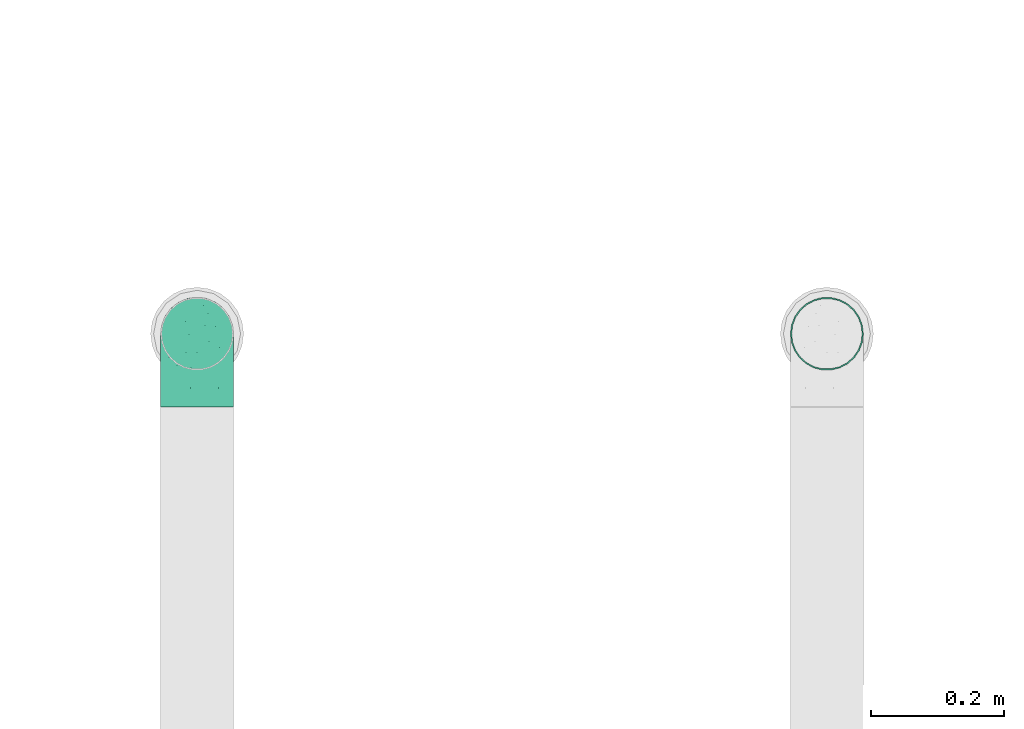
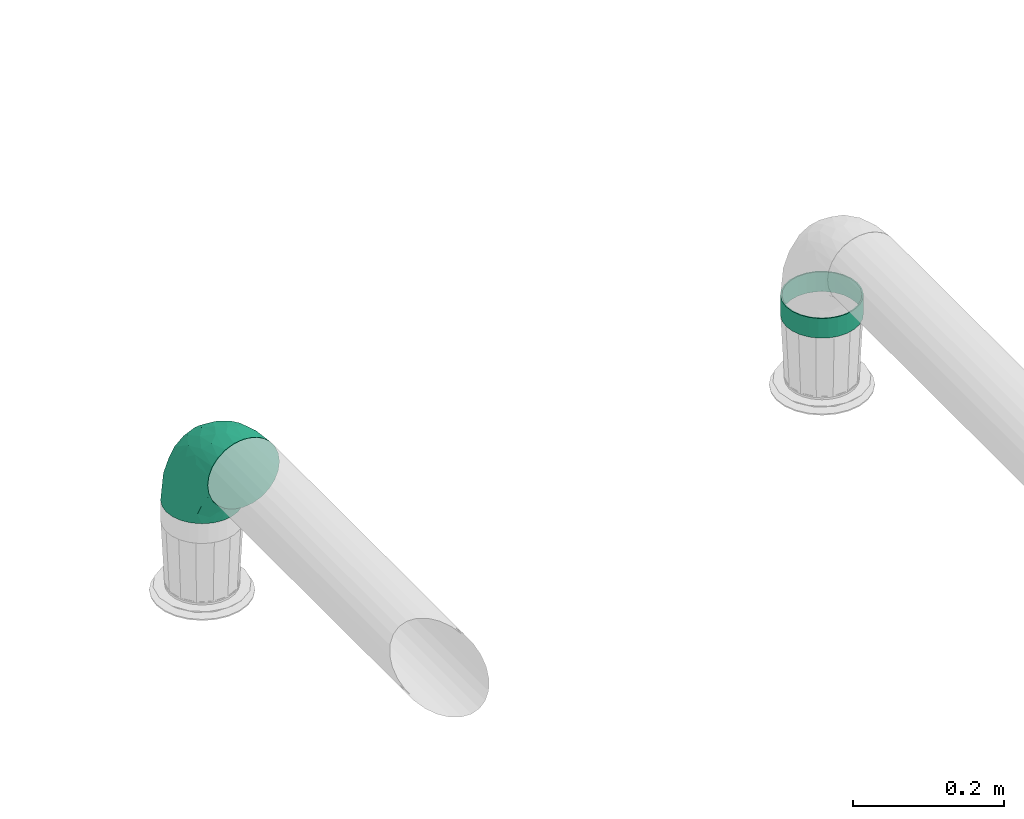
# One storey, part 43 of 123: 1 flow fitting, 1 flow segment.
"""IFC2X3 building model written with IfcOpenShell, lengths in millimetres."""

from ifc_helpers import new_model, entity, si_unit, converted_unit, derived_unit, direction, frame, origin_with_axes, origin_2d_with_axis, place, context, subcontext, project, spatial, hollow_circle, extrude, open_shell, surface_model, source, transform, mapped, material, layer, layer_set, layer_usage, type_object, element, save


model = new_model("IFC2X3")

# Units and contexts
model_context = context("Model", 3, precision=1e-05, world=origin_with_axes(), true_north=direction((0.0, 1.0)))
body_context = subcontext(model_context, "Body", "Model", "MODEL_VIEW")
ifc_project = project(units=[si_unit("AREAUNIT", "SQUARE_METRE"), si_unit("VOLUMEUNIT", "CUBIC_METRE", prefix="DECI"), si_unit("TIMEUNIT", "SECOND"), si_unit("THERMODYNAMICTEMPERATUREUNIT", "DEGREE_CELSIUS"), si_unit("PRESSUREUNIT", "PASCAL"), si_unit("MASSUNIT", "GRAM", prefix="KILO"), si_unit("LENGTHUNIT", "METRE", prefix="MILLI"), si_unit("POWERUNIT", "WATT"), si_unit("ELECTRICCURRENTUNIT", "AMPERE"), si_unit("ELECTRICVOLTAGEUNIT", "VOLT"), derived_unit("VOLUMETRICFLOWRATEUNIT", [(si_unit("VOLUMEUNIT", "CUBIC_METRE", prefix="DECI"), 1), (si_unit("TIMEUNIT", "SECOND"), -1)]), derived_unit("LINEARVELOCITYUNIT", [(si_unit("LENGTHUNIT", "METRE"), 1), (si_unit("TIMEUNIT", "SECOND"), -1)]), derived_unit("MASSDENSITYUNIT", [(si_unit("MASSUNIT", "GRAM", prefix="KILO"), 1), (si_unit("VOLUMEUNIT", "CUBIC_METRE"), -1)]), converted_unit("PLANEANGLEUNIT", "DEGREE", entity("IfcRatioMeasure", 0.01745), si_unit("PLANEANGLEUNIT", "RADIAN"), dimensions=[0, 0, 0, 0, 0, 0, 0])], contexts=[model_context])

# Site, building, storey
site_placement = place(None, origin_with_axes())
site = spatial("IfcSite", under=ifc_project, at=site_placement, CompositionType="ELEMENT")
building_placement = place(site_placement, origin_with_axes())
building = spatial("IfcBuilding", under=site, at=building_placement, Name="mc-building", CompositionType="ELEMENT")
storey_placement = place(building_placement, origin_with_axes())
storey = spatial("IfcBuildingStorey", under=building, at=storey_placement, Name="1. Korrus", CompositionType="ELEMENT", Elevation=0.0)

# Flow segment
ifc_material = material(Name="FZ1")
ifc_layer = layer(ifc_material, 0.0)
ifc_layer_set = layer_set([ifc_layer], Name="FZ1")
ifc_layer_usage = layer_usage(ifc_layer_set, "AXIS1", "POSITIVE", 0.0)
duct_segment_type = type_object("IfcDuctSegmentType", PredefinedType="RIGIDSEGMENT")
shared_shape_1 = source(origin_with_axes(), body_context, "Body", "SweptSolid", [
    extrude(hollow_circle(Radius=55.0, WallThickness=2.0, at=origin_2d_with_axis()), frame((0.0, 0.0, 0.0), z_axis=(1.0, 0.0, 0.0), x_axis=(0.0, 1.0, 0.0)), (0.0, 0.0, 1.0), 31.9),
])
flow_segment_placement = place(storey_placement, frame((16466.11947, 4715.81442, 2335.0), z_axis=(0.0, 1.0, 0.0), x_axis=(0.0, 0.0, -1.0)))
element("IfcFlowSegment", 1, at=flow_segment_placement, inside=storey, type_object=duct_segment_type, material=ifc_layer_usage, context=body_context, shape_type="MappedRepresentation", body=[
    mapped(shared_shape_1, transform((0.0, 0.0, 0.0), scale=1.0)),
])

# Flow fitting
duct_fitting_type = type_object("IfcDuctFittingType", Name="BU", PredefinedType="BEND")
shared_shape_2 = source(origin_with_axes(), body_context, "Body", "SurfaceModel", [
    surface_model("IfcShellBasedSurfaceModel", [(-110.0, -38.89087, -38.89087), (-110.0, -55.0, 0.0), (-110.0, -27.5, -47.63139), (-110.0, -53.12592, -14.23505), (-110.0, -47.63139, -27.5), (-110.0, 47.63139, -27.5), (-110.0, 53.12592, 14.23505), (-110.0, 53.12592, -14.23505), (-110.0, -14.23505, -53.12592), (-110.0, 0.0, -55.0), (-110.0, 38.89087, -38.89087), (-110.0, 27.5, -47.63139), (-110.0, 14.23505, -53.12592), (-110.0, 55.0, 0.0), (-110.0, -53.12592, 14.23505), (-110.0, -47.63139, 27.5), (-110.0, -38.89087, 38.89087), (-110.0, 0.0, 55.0), (-110.0, -27.5, 47.63139), (-110.0, -14.23505, 53.12592), (-110.0, 38.89087, 38.89087), (-110.0, 47.63139, 27.5), (-110.0, 27.5, 47.63139), (-110.0, 14.23505, 53.12592), (0.0, -110.0, -55.0), (14.23505, -110.0, -53.12592), (-14.23505, -110.0, -53.12592), (-53.12592, -110.0, 14.23505), (-27.5, -110.0, -47.63139), (-47.63139, -110.0, -27.5), (-38.89087, -110.0, -38.89087), (55.0, -110.0, 0.0), (53.12592, -110.0, 14.23505), (38.89087, -110.0, -38.89087), (27.5, -110.0, -47.63139), (53.12592, -110.0, -14.23505), (47.63139, -110.0, -27.5), (-53.12592, -110.0, -14.23505), (-47.63139, -110.0, 27.5), (-38.89087, -110.0, 38.89087), (14.23505, -110.0, 53.12592), (-27.5, -110.0, 47.63139), (-14.23505, -110.0, 53.12592), (47.63139, -110.0, 27.5), (38.89087, -110.0, 38.89087), (27.5, -110.0, 47.63139), (0.0, -110.0, 55.0), (-55.0, -110.0, 0.0), (-60.44912, -32.56953, 51.94617), (-76.6405, -38.18013, 45.55988), (-64.21732, -48.68956, 43.63444), (-90.15553, -11.94394, 54.09138), (-76.00813, -5.38378, 55.0), (-70.18771, -18.55163, 54.03432), (-78.5998, -26.77405, 50.81338), (-93.27622, -45.77614, 33.48188), (-75.55424, -54.2118, 32.41257), (-96.12334, -22.13664, 50.81337), (-32.04182, -59.64019, 52.24446), (-18.36258, -70.48427, 54.04484), (-21.00813, -45.34362, 55.0), (-63.60674, -66.07878, 29.97482), (-74.66383, -63.08407, 19.92123), (-63.88653, -74.77858, 17.99134), (-93.11138, -56.59448, 10.50359), (-99.597, -52.72185, 18.52927), (-98.21577, -57.34403, 0.0), (-53.42855, -92.60092, 21.04759), (-88.54852, -54.8376, 21.04759), (-5.38378, -76.00813, 55.0), (-11.86161, -90.23965, 54.10313), (-56.64619, -93.12774, 10.22088), (-57.34403, -98.21577, 0.0), (-44.60838, -44.60838, 52.13415), (-45.34362, -21.00813, 55.0), (-92.68484, -35.46673, 43.63443), (-22.25266, -95.40765, 50.81337), (-27.23711, -77.39884, 50.81337), (-43.70931, -69.58671, 44.47149), (-35.97783, -90.61597, 43.63443), (-58.67786, -84.31125, 16.04456), (-57.2828, -79.3123, 24.9774), (-82.93277, -60.36161, 12.91784), (-49.88337, -54.51816, 47.224), (-74.57753, -66.83759, 9.55742), (-45.35812, -94.97281, 33.48188), (-59.18663, -88.95241, 0.0), (-51.517, -78.6292, 33.48188), (-65.14788, -80.03077, 0.0), (-56.45322, -62.06476, 39.63545), (-88.95241, -59.18663, 0.0), (-80.03077, -65.14788, 0.0), (-71.10913, -71.10913, 0.0), (-94.9309, -45.36788, -33.48188), (-93.11358, -56.60141, -10.46614), (-99.64997, -52.79499, -18.30015), (-79.99933, -46.56772, -37.92748), (-90.20425, -36.08686, -43.63443), (-45.34362, -21.00813, -55.0), (-72.75364, -19.68651, -53.60527), (-76.00813, -5.38378, -55.0), (-21.00813, -45.34362, -55.0), (-5.38378, -76.00813, -55.0), (-21.91957, -65.12078, -53.85897), (-35.41876, -92.89265, -43.63443), (-91.10309, -11.02766, -54.21832), (-45.77614, -93.27622, -33.48188), (-90.50474, -23.21022, -50.81337), (-70.92854, -33.31794, -49.51754), (-78.52933, -63.35627, -11.73997), (-24.91508, -84.05606, -50.81337), (-88.78941, -54.74452, -21.04759), (-63.49062, -67.59111, -28.46929), (-73.36422, -62.46673, -22.94182), (-69.59921, -57.34866, -33.48187), (-56.59448, -93.11138, -10.50359), (-54.10679, -75.85581, -32.31867), (-54.8376, -88.54852, -21.04759), (-57.75956, -31.09612, -52.80882), (-52.72185, -99.597, -18.52927), (-12.62913, -89.46304, -53.99097), (-34.46825, -66.46123, -50.04329), (-43.9837, -43.9837, -52.42279), (-65.78527, -72.58348, -17.68796), (-57.47001, -51.99467, -44.91465), (-70.34468, -43.65295, -44.21951), (-60.72547, -82.29174, -12.88567), (-42.34915, -74.24548, -43.63444), (-57.25194, -63.5016, -38.08211), (-80.95344, -53.56991, -29.32027), (-52.32891, -4.55257, -54.0482), (14.95561, -36.05775, -42.26543), (14.88266, -20.92917, -33.7947), (32.52942, -47.13398, -30.48571), (19.3559, -65.35825, -48.00507), (30.24048, -70.09027, -41.7461), (-28.49299, 30.5778, -16.4009), (-47.13398, 32.52942, -30.48571), (-70.35075, 46.44478, -19.5952), (-22.4954, -22.4954, -53.25347), (-4.55257, -52.32891, -54.0482), (-75.47368, 11.22546, -52.60718), (-81.32209, 51.5606, -9.98467), (-70.09027, 30.24048, -41.7461), (-80.81763, 41.84862, -32.14655), (-9.15831, 10.852, -27.8997), (-36.05774, 14.95561, -42.26543), (-65.35825, 19.3559, -48.00507), (3.94376, -43.9333, -50.53315), (11.22546, -75.47368, -52.60718), (-43.9333, 3.94376, -50.53315), (-13.39742, -13.39743, -48.13058), (50.20582, -74.51695, -9.9731), (41.8609, -47.82256, -9.92641), (49.37776, -67.29486, 0.0), (18.93131, -11.7156, -17.56239), (-1.23348, 12.25375, -12.18106), (-27.5, 32.89419, 0.0), (41.84862, -80.81763, -32.14655), (46.44478, -70.35075, -19.5952), (35.70604, -41.31408, -20.38235), (6.67262, 6.67262, 0.0), (32.89419, -27.5, 0.0), (-50.36265, 42.95545, -9.51562), (-67.29486, 49.37776, 0.0), (-5.47251, -5.47251, -39.92906), (-70.35075, 46.44478, 19.5952), (-74.51695, 50.20582, 9.9731), (-47.13398, 32.52942, 30.48571), (-41.31407, 35.70604, 20.38235), (-80.81763, 41.84862, 32.14655), (11.22546, -75.47368, 52.60718), (-4.55257, -52.32891, 54.0482), (-36.05774, 14.95561, 42.26543), (-65.35825, 19.3559, 48.00507), (-43.9333, 3.94376, 50.53315), (-70.09027, 30.24048, 41.7461), (-11.7156, 18.93131, 17.56239), (12.25375, -1.23348, 12.18106), (30.5778, -28.49299, 16.4009), (42.95545, -50.36265, 9.51562), (51.5606, -81.32209, 9.98467), (-52.32891, -4.55257, 54.0482), (-75.47368, 11.22546, 52.60718), (-13.39742, -13.39743, 48.13058), (-22.4954, -22.4954, 53.25347), (3.94376, -43.9333, 50.53315), (-20.92916, 14.88266, 33.79469), (10.852, -9.15831, 27.8997), (-47.82256, 41.8609, 9.92641), (32.52942, -47.13398, 30.48571), (46.44478, -70.35075, 19.5952), (41.84862, -80.81763, 32.14655), (14.95561, -36.05775, 42.26543), (19.3559, -65.35825, 48.00507), (30.24048, -70.09027, 41.7461), (-5.47251, -5.47251, 39.92906)], [open_shell([[[0, 1, 2]], [[3, 1, 4]], [[5, 6, 7]], [[8, 1, 9]], [[2, 1, 8]], [[4, 1, 0]], [[10, 9, 6]], [[9, 10, 11]], [[11, 12, 9]], [[6, 5, 10]], [[7, 6, 13]], [[14, 15, 9]], [[9, 15, 16]], [[17, 16, 18]], [[9, 16, 17]], [[19, 17, 18]], [[9, 20, 21]], [[6, 9, 21]], [[9, 22, 20]], [[23, 22, 9]], [[17, 23, 9]], [[9, 1, 14]], [[24, 25, 26]], [[26, 27, 28]], [[29, 30, 27]], [[28, 27, 30]], [[26, 31, 32]], [[33, 31, 34]], [[25, 34, 31]], [[35, 31, 36]], [[33, 36, 31]], [[31, 26, 25]], [[29, 27, 37]], [[38, 27, 26]], [[39, 38, 26]], [[40, 41, 26]], [[41, 39, 26]], [[40, 42, 41]], [[43, 44, 26]], [[43, 26, 32]], [[44, 45, 26]], [[26, 45, 40]], [[40, 46, 42]], [[47, 37, 27]], [[48, 49, 50]], [[51, 52, 17]], [[48, 53, 54]], [[49, 55, 56]], [[16, 15, 55]], [[18, 57, 19]], [[58, 59, 60]], [[61, 62, 63]], [[64, 65, 14]], [[53, 51, 54]], [[66, 64, 14]], [[27, 38, 67]], [[65, 68, 55]], [[68, 65, 64]], [[69, 59, 70]], [[71, 72, 27]], [[73, 60, 74]], [[55, 49, 75]], [[42, 70, 76]], [[51, 57, 54]], [[77, 78, 79]], [[42, 76, 41]], [[46, 70, 42]], [[55, 68, 56]], [[75, 18, 16]], [[77, 79, 76]], [[80, 67, 81]], [[68, 82, 62]], [[83, 78, 58]], [[82, 84, 62]], [[39, 79, 85]], [[71, 67, 80]], [[72, 71, 86]], [[67, 85, 87]], [[88, 80, 63]], [[39, 41, 79]], [[87, 79, 78]], [[55, 75, 16]], [[50, 89, 83]], [[38, 39, 85]], [[56, 68, 62]], [[61, 87, 89]], [[48, 50, 83]], [[18, 75, 57]], [[54, 75, 49]], [[38, 85, 67]], [[85, 79, 87]], [[56, 62, 61]], [[50, 56, 89]], [[87, 61, 81]], [[90, 64, 66]], [[14, 1, 66]], [[91, 92, 84]], [[82, 90, 91]], [[90, 82, 64]], [[62, 84, 63]], [[84, 82, 91]], [[64, 82, 68]], [[65, 15, 14]], [[15, 65, 55]], [[72, 47, 27]], [[86, 71, 80]], [[67, 71, 27]], [[88, 63, 92]], [[63, 80, 81]], [[63, 81, 61]], [[87, 81, 67]], [[41, 76, 79]], [[70, 59, 77]], [[76, 70, 77]], [[69, 70, 46]], [[77, 59, 58]], [[59, 69, 60]], [[77, 58, 78]], [[73, 58, 60]], [[19, 57, 51]], [[54, 57, 75]], [[19, 51, 17]], [[53, 52, 51]], [[53, 74, 52]], [[73, 74, 48]], [[53, 48, 74]], [[83, 73, 48]], [[73, 83, 58]], [[78, 83, 89]], [[78, 89, 87]], [[61, 89, 56]], [[54, 49, 48]], [[50, 49, 56]], [[88, 86, 80]], [[63, 84, 92]], [[93, 4, 0]], [[66, 94, 90]], [[95, 94, 3]], [[96, 93, 97]], [[98, 99, 100]], [[0, 2, 97]], [[101, 102, 103]], [[104, 28, 30]], [[9, 105, 8]], [[30, 106, 104]], [[107, 105, 99]], [[97, 107, 108]], [[94, 109, 90]], [[2, 8, 107]], [[94, 66, 3]], [[110, 26, 28]], [[94, 111, 109]], [[112, 113, 114]], [[72, 115, 37]], [[116, 106, 117]], [[98, 118, 99]], [[119, 115, 117]], [[115, 119, 37]], [[110, 120, 26]], [[103, 110, 121]], [[117, 106, 119]], [[120, 110, 103]], [[98, 101, 122]], [[117, 123, 116]], [[108, 124, 125]], [[126, 117, 115]], [[30, 29, 106]], [[120, 102, 24]], [[110, 104, 127]], [[97, 125, 96]], [[118, 122, 124]], [[124, 127, 128]], [[93, 0, 97]], [[86, 126, 115]], [[127, 106, 116]], [[129, 113, 111]], [[4, 93, 95]], [[114, 129, 96]], [[28, 104, 110]], [[127, 104, 106]], [[2, 107, 97]], [[108, 107, 99]], [[118, 108, 99]], [[100, 99, 105]], [[128, 112, 114]], [[127, 124, 121]], [[66, 1, 3]], [[91, 90, 109]], [[95, 111, 94]], [[109, 123, 92]], [[114, 113, 129]], [[111, 95, 93]], [[95, 3, 4]], [[86, 115, 72]], [[37, 47, 72]], [[88, 92, 123]], [[123, 117, 126]], [[126, 88, 123]], [[88, 126, 86]], [[119, 29, 37]], [[29, 119, 106]], [[111, 93, 129]], [[124, 114, 125]], [[100, 105, 9]], [[8, 105, 107]], [[108, 118, 124]], [[122, 118, 98]], [[96, 129, 93]], [[109, 111, 113]], [[113, 123, 109]], [[116, 123, 112]], [[113, 112, 123]], [[116, 112, 128]], [[116, 128, 127]], [[124, 128, 114]], [[103, 122, 101]], [[127, 121, 110]], [[121, 122, 103]], [[122, 121, 124]], [[26, 120, 24]], [[102, 120, 103]], [[108, 125, 97]], [[109, 92, 91]], [[96, 125, 114]], [[100, 130, 98]], [[131, 132, 133]], [[134, 135, 34]], [[136, 137, 138]], [[101, 139, 140]], [[9, 141, 100]], [[138, 7, 142]], [[137, 143, 144]], [[142, 7, 13]], [[145, 146, 137]], [[146, 147, 143]], [[5, 138, 144]], [[7, 138, 5]], [[5, 144, 10]], [[140, 148, 149]], [[143, 11, 10]], [[147, 12, 11]], [[100, 141, 130]], [[98, 139, 101]], [[148, 134, 149]], [[139, 150, 151]], [[152, 153, 154]], [[150, 139, 130]], [[25, 24, 149]], [[141, 12, 147]], [[132, 145, 155]], [[156, 136, 157]], [[158, 33, 135]], [[148, 139, 151]], [[36, 33, 158]], [[34, 135, 33]], [[159, 160, 153]], [[160, 159, 133]], [[137, 146, 143]], [[152, 154, 31]], [[137, 136, 145]], [[161, 162, 155]], [[133, 159, 158]], [[134, 148, 131]], [[163, 164, 157]], [[163, 142, 164]], [[102, 101, 140]], [[162, 154, 153]], [[159, 35, 36]], [[155, 156, 161]], [[131, 165, 132]], [[155, 145, 156]], [[98, 130, 139]], [[150, 130, 141]], [[147, 150, 141]], [[9, 12, 141]], [[149, 24, 102]], [[148, 140, 139]], [[140, 149, 102]], [[34, 25, 134]], [[146, 151, 150]], [[143, 147, 11]], [[147, 146, 150]], [[145, 165, 146]], [[25, 149, 134]], [[135, 134, 131]], [[135, 131, 133]], [[151, 165, 131]], [[148, 151, 131]], [[165, 151, 146]], [[160, 133, 132]], [[132, 165, 145]], [[36, 158, 159]], [[133, 158, 135]], [[10, 144, 143]], [[137, 144, 138]], [[162, 153, 155]], [[159, 153, 152]], [[160, 155, 153]], [[155, 160, 132]], [[152, 35, 159]], [[35, 152, 31]], [[136, 138, 163]], [[164, 142, 13]], [[142, 163, 138]], [[136, 163, 157]], [[161, 156, 157]], [[136, 156, 145]], [[166, 6, 21]], [[167, 164, 13]], [[166, 168, 169]], [[170, 168, 166]], [[69, 171, 172]], [[173, 174, 175]], [[174, 176, 22]], [[161, 157, 177]], [[170, 20, 176]], [[21, 20, 170]], [[178, 179, 162]], [[180, 181, 154]], [[182, 175, 183]], [[183, 23, 17]], [[184, 185, 186]], [[74, 185, 182]], [[52, 74, 182]], [[187, 188, 177]], [[166, 169, 189]], [[190, 179, 188]], [[22, 176, 20]], [[180, 154, 162]], [[32, 191, 43]], [[192, 44, 43]], [[43, 191, 192]], [[32, 31, 181]], [[193, 194, 195]], [[194, 40, 45]], [[190, 193, 195]], [[45, 44, 195]], [[69, 46, 171]], [[74, 60, 185]], [[157, 164, 189]], [[167, 189, 164]], [[172, 60, 69]], [[185, 172, 186]], [[173, 187, 168]], [[191, 32, 181]], [[190, 195, 192]], [[179, 190, 191]], [[175, 174, 183]], [[171, 40, 194]], [[188, 193, 190]], [[175, 185, 184]], [[177, 178, 161]], [[173, 196, 187]], [[177, 188, 178]], [[60, 172, 185]], [[186, 172, 171]], [[194, 186, 171]], [[46, 40, 171]], [[183, 17, 52]], [[175, 182, 185]], [[182, 183, 52]], [[22, 23, 174]], [[193, 184, 186]], [[195, 194, 45]], [[194, 193, 186]], [[188, 196, 193]], [[23, 183, 174]], [[176, 174, 173]], [[176, 173, 168]], [[184, 196, 173]], [[175, 184, 173]], [[196, 184, 193]], [[169, 168, 187]], [[187, 196, 188]], [[21, 170, 166]], [[168, 170, 176]], [[44, 192, 195]], [[190, 192, 191]], [[157, 189, 177]], [[166, 189, 167]], [[169, 177, 189]], [[177, 169, 187]], [[167, 6, 166]], [[6, 167, 13]], [[179, 191, 180]], [[154, 181, 31]], [[181, 180, 191]], [[179, 180, 162]], [[161, 178, 162]], [[179, 178, 188]]])]),
])
flow_fitting_placement = place(storey_placement, frame((15517.82156, 4715.81442, 2445.0), z_axis=(-1.0, 0.0, 0.0), x_axis=(0.0, 0.0, 1.0)))
element("IfcFlowFitting", 2, at=flow_fitting_placement, inside=storey, type_object=duct_fitting_type, Name="BU", context=body_context, shape_type="MappedRepresentation", body=[
    mapped(shared_shape_2, transform((0.0, 0.0, 0.0), scale=1.0)),
])

save(model, "model.ifc")
